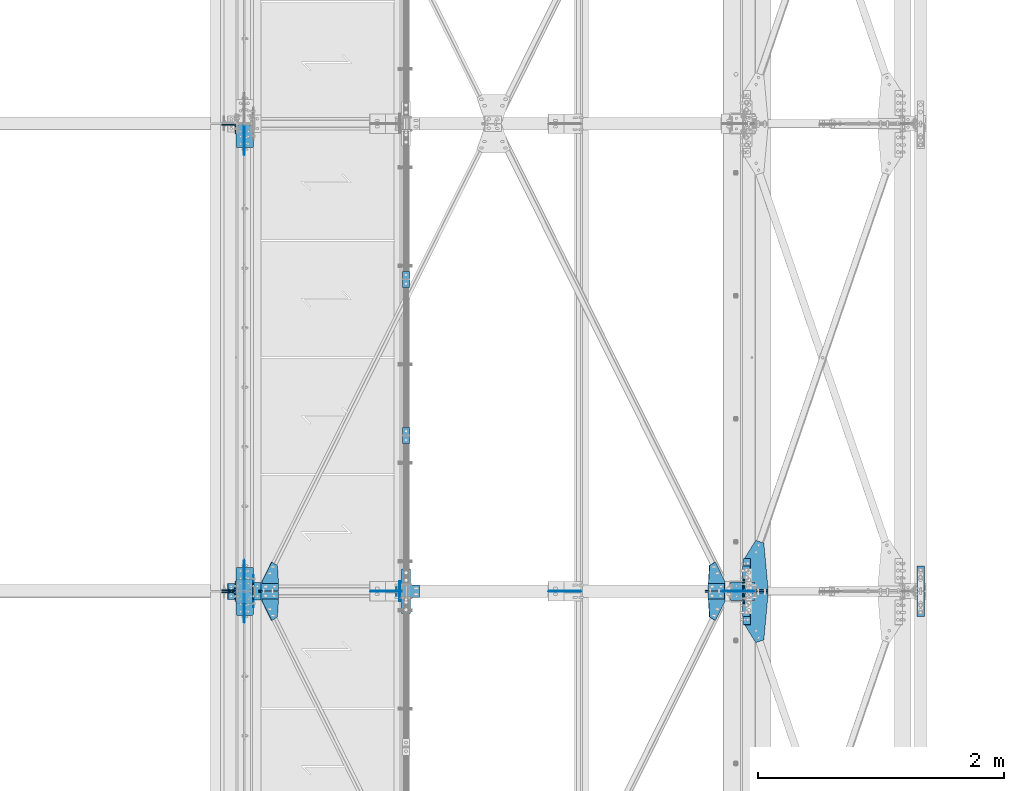
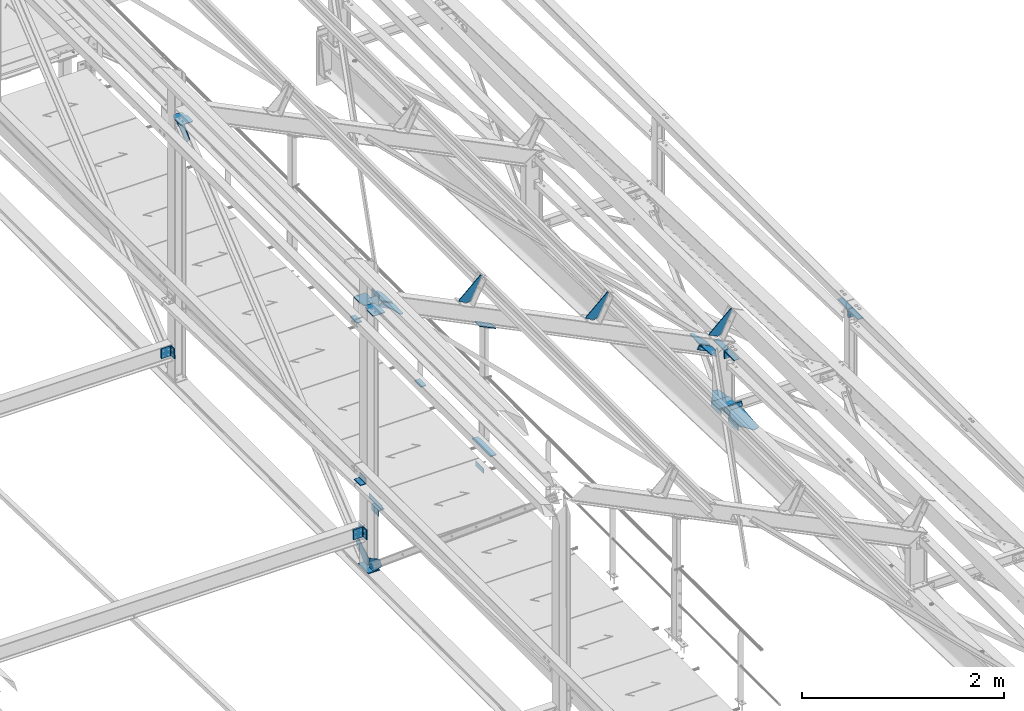
# One storey, part 108 of 496: 30 beams, 10 members, 31 elements without a shape of their own.
"""IFC2X3 building model written with IfcOpenShell, lengths in millimetres."""

from ifc_helpers import new_model, si_unit, frame, frame_2d, origin_with_axes, origin_2d_with_axis, place, context, subcontext, project, spatial, polyline, circle_curve, parameter, trimmed, segment, composite_curve, rectangle, l_section, outline, extrude, material, type_object, element, aggregate, save


model = new_model("IFC2X3")

# Units and contexts
model_context = context("Model", 3, precision=1e-05, world=origin_with_axes())
body_context = subcontext(model_context, "Body", "Model", "MODEL_VIEW")
ifc_project = project(units=[si_unit("LENGTHUNIT", "METRE", prefix="MILLI"), si_unit("AREAUNIT", "SQUARE_METRE"), si_unit("VOLUMEUNIT", "CUBIC_METRE"), si_unit("MASSUNIT", "GRAM", prefix="KILO"), si_unit("TIMEUNIT", "SECOND"), si_unit("PLANEANGLEUNIT", "RADIAN"), si_unit("SOLIDANGLEUNIT", "STERADIAN"), si_unit("THERMODYNAMICTEMPERATUREUNIT", "DEGREE_CELSIUS"), si_unit("LUMINOUSINTENSITYUNIT", "LUMEN")], contexts=[model_context])

# Site, building, storey
site_placement = place(None, origin_with_axes())
site = spatial("IfcSite", under=ifc_project, at=site_placement, CompositionType="ELEMENT")
building_placement = place(site_placement, origin_with_axes())
building = spatial("IfcBuilding", under=site, at=building_placement, Name="Undefined", CompositionType="ELEMENT")
storey_placement = place(building_placement, origin_with_axes())
storey = spatial("IfcBuildingStorey", under=building, at=storey_placement, Name="Undefined", CompositionType="ELEMENT", Elevation=0.0)

# Assembly, beams
assembly_1_placement = place(storey_placement, origin_with_axes())
assembly_1 = element("IfcElementAssembly", 1, at=assembly_1_placement, inside=storey, Name="MAIN COURANTE", AssemblyPlace="NOTDEFINED", PredefinedType="NOTDEFINED")
ifc_material = material(Name="Undefined/S235-E24")
beam_type_1 = type_object("IfcBeamType", PredefinedType="NOTDEFINED")
beam_1_placement = place(assembly_1_placement, frame((35593.9917177843, 8930.00343196749, 8245.00000278714), z_axis=(-1.0, 0.0, 0.0), x_axis=(0.0, -1.0, 0.0)))
beam_1 = element("IfcBeam", 2, at=beam_1_placement, type_object=beam_type_1, material=ifc_material, context=body_context, shape_type="SweptSolid", body=[
    extrude(rectangle(XDim=10.0, YDim=60.0, at=origin_2d_with_axis()), frame((130.0, 0.0, 0.0), z_axis=(-1.0, 0.0, 0.0), x_axis=(0.0, -1.0, 0.0)), (0.0, 0.0, 1.0), 130.0),
])
beam_2_placement = place(assembly_1_placement, frame((35593.9917188389, 10200.0034319675, 8245.00000191645), z_axis=(-1.0, 0.0, 0.0), x_axis=(0.0, -1.0, 0.0)))
beam_2 = element("IfcBeam", 3, at=beam_2_placement, type_object=beam_type_1, material=ifc_material, context=body_context, shape_type="SweptSolid", body=[
    extrude(rectangle(XDim=10.0, YDim=60.0, at=origin_2d_with_axis()), frame((130.0, 0.0, 0.0), z_axis=(-1.0, 0.0, 0.0), x_axis=(0.0, -1.0, 0.0)), (0.0, 0.0, 1.0), 130.0),
])
aggregate(assembly_1, [beam_1, beam_2])

# Assembly, beam
assembly_2_placement = place(storey_placement, origin_with_axes())
assembly_2 = element("IfcElementAssembly", 4, at=assembly_2_placement, inside=storey, AssemblyPlace="NOTDEFINED", PredefinedType="NOTDEFINED")
beam_type_2 = type_object("IfcBeamType", PredefinedType="NOTDEFINED")
beam_3_placement = place(assembly_2_placement, frame((38365.0000000024, 7527.01910210881, 7657.37684430103), z_axis=(0.0, -0.031410887010906, -0.999506556345274), x_axis=(0.0, -0.999506556345276, 0.031410887010852)))
beam_3 = element("IfcBeam", 5, at=beam_3_placement, type_object=beam_type_2, material=ifc_material, context=body_context, shape_type="SweptSolid", body=[
    extrude(l_section(Depth=60.0, Width=60.0, Thickness=6.0, FilletRadius=8.0, EdgeRadius=4.0, at=origin_2d_with_axis()), frame((200.0, 0.0, 0.0), z_axis=(-1.0, 0.0, 0.0), x_axis=(0.0, -1.0, 0.0)), (0.0, 0.0, 1.0), 200.0),
])
aggregate(assembly_2, [beam_3])

assembly_3_placement = place(storey_placement, origin_with_axes())
assembly_3 = element("IfcElementAssembly", 6, at=assembly_3_placement, inside=storey, AssemblyPlace="NOTDEFINED", PredefinedType="NOTDEFINED")
beam_4_placement = place(assembly_3_placement, frame((38365.0000000024, 7866.85133378981, 7646.69722298247), z_axis=(0.0, -0.031410887010906, -0.999506556345274), x_axis=(0.0, -0.999506556345276, 0.031410887010852)))
beam_4 = element("IfcBeam", 7, at=beam_4_placement, type_object=beam_type_2, material=ifc_material, context=body_context, shape_type="SweptSolid", body=[
    extrude(l_section(Depth=60.0, Width=60.0, Thickness=6.0, FilletRadius=8.0, EdgeRadius=4.0, at=origin_2d_with_axis()), frame((200.0, 0.0, 0.0), z_axis=(-1.0, 0.0, 0.0), x_axis=(0.0, -1.0, 0.0)), (0.0, 0.0, 1.0), 200.0),
])
aggregate(assembly_3, [beam_4])

assembly_4_placement = place(storey_placement, origin_with_axes())
assembly_4 = element("IfcElementAssembly", 8, at=assembly_4_placement, inside=storey, Name="TRAVERSE SHED", AssemblyPlace="NOTDEFINED", PredefinedType="NOTDEFINED")
beam_type_3 = type_object("IfcBeamType", PredefinedType="NOTDEFINED")
beam_5_placement = place(assembly_4_placement, frame((38330.0, 7674.80562184453, 7813.81292929363), z_axis=(-1.0, 0.0, 0.0), x_axis=(0.0, -0.999506556345276, 0.031410887010852)))
beam_5 = element("IfcBeam", 9, at=beam_5_placement, type_object=beam_type_3, material=ifc_material, context=body_context, shape_type="SweptSolid", body=[
    extrude(rectangle(XDim=10.0, YDim=200.0, at=origin_2d_with_axis()), frame((149.999995982835, 4.54747350886464e-12, 3.63797880709171e-12), z_axis=(-1.0, 0.0, 0.0), x_axis=(0.0, -1.0, 0.0)), (0.0, 0.0, 1.0), 150.0),
])

assembly_5_placement = place(storey_placement, origin_with_axes())
assembly_5 = element("IfcElementAssembly", 10, at=assembly_5_placement, inside=storey, AssemblyPlace="NOTDEFINED", PredefinedType="NOTDEFINED")
beam_type_4 = type_object("IfcBeamType", PredefinedType="NOTDEFINED")
beam_6_placement = place(assembly_5_placement, frame((34381.5000576363, 7530.0, 7915.0), z_axis=(1.0, 0.0, 0.0), x_axis=(0.0, 1.0, 0.0)))
beam_6 = element("IfcBeam", 11, at=beam_6_placement, type_object=beam_type_4, material=ifc_material, context=body_context, shape_type="SweptSolid", body=[
    extrude(l_section(Depth=70.0, Width=70.0, Thickness=7.0, FilletRadius=9.0, EdgeRadius=4.5, at=origin_2d_with_axis()), frame((140.0, 0.0, 0.0), z_axis=(-1.0, 0.0, 0.0), x_axis=(0.0, -1.0, 0.0)), (0.0, 0.0, 1.0), 140.0),
])
aggregate(assembly_5, [beam_6])

assembly_6_placement = place(storey_placement, origin_with_axes())
assembly_6 = element("IfcElementAssembly", 12, at=assembly_6_placement, inside=storey, AssemblyPlace="NOTDEFINED", PredefinedType="NOTDEFINED")
beam_7_placement = place(assembly_6_placement, frame((34178.5001163161, 7664.81291402424, 8349.41493629771), z_axis=(0.0, 0.0314135610096692, 0.999506472307554), x_axis=(0.0, -0.999506472307554, 0.031413561009669)))
beam_7 = element("IfcBeam", 13, at=beam_7_placement, type_object=beam_type_4, material=ifc_material, context=body_context, shape_type="SweptSolid", body=[
    extrude(l_section(Depth=70.0, Width=70.0, Thickness=7.0, FilletRadius=9.0, EdgeRadius=4.5, at=origin_2d_with_axis()), frame((130.004127993981, 0.0, 9.02084851220212e-16), z_axis=(-1.0, 0.0, 0.0), x_axis=(0.0, -1.0, 0.0)), (0.0, 0.0, 1.0), 130.0),
])
aggregate(assembly_6, [beam_7])

# Assembly, member
assembly_7_placement = place(storey_placement, origin_with_axes())
assembly_7 = element("IfcElementAssembly", 14, at=assembly_7_placement, inside=storey, AssemblyPlace="NOTDEFINED", PredefinedType="NOTDEFINED")
member_type_1 = type_object("IfcMemberType", PredefinedType="NOTDEFINED")
member_1_placement = place(assembly_7_placement, frame((38035.9186042642, 7567.00048471499, 8592.20874331215), z_axis=(0.0, -1.0, 0.0), x_axis=(0.897398510539058, 0.0, -0.441220934773362)))
member_1 = element("IfcMember", 15, at=member_1_placement, type_object=member_type_1, material=ifc_material, context=body_context, shape_type="SweptSolid", body=[
    extrude(l_section(Depth=60.0, Width=60.0, Thickness=6.0, FilletRadius=8.0, EdgeRadius=4.0, at=origin_2d_with_axis()), frame((149.999995982835, 4.54747350886464e-12, 3.63797880709171e-12), z_axis=(-1.0, 0.0, 0.0), x_axis=(0.0, -1.0, 0.0)), (0.0, 0.0, 1.0), 150.0),
])
aggregate(assembly_7, [member_1])

assembly_8_placement = place(storey_placement, origin_with_axes())
assembly_8 = element("IfcElementAssembly", 16, at=assembly_8_placement, inside=storey, AssemblyPlace="NOTDEFINED", PredefinedType="NOTDEFINED")
member_2_placement = place(assembly_8_placement, frame((38170.5284284906, 7633.00028154396, 8526.02570190095), z_axis=(0.0, 1.0, 0.0), x_axis=(-0.897398834350847, -3.60000012672484e-08, 0.441220276172504)))
member_2 = element("IfcMember", 17, at=member_2_placement, type_object=member_type_1, material=ifc_material, context=body_context, shape_type="SweptSolid", body=[
    extrude(l_section(Depth=60.0, Width=60.0, Thickness=6.0, FilletRadius=8.0, EdgeRadius=4.0, at=origin_2d_with_axis()), frame((149.999995982835, 4.54747350886464e-12, 3.63797880709171e-12), z_axis=(-1.0, 0.0, 0.0), x_axis=(0.0, -1.0, 0.0)), (0.0, 0.0, 1.0), 150.0),
])
aggregate(assembly_8, [member_2])

assembly_9_placement = place(storey_placement, origin_with_axes())
assembly_9 = element("IfcElementAssembly", 18, at=assembly_9_placement, inside=storey, AssemblyPlace="NOTDEFINED", PredefinedType="NOTDEFINED")
member_3_placement = place(assembly_9_placement, frame((34407.7040963335, 7567.00042689714, 10376.0796849426), z_axis=(0.0, -1.0, 0.0), x_axis=(0.897398510539058, 0.0, -0.441220934773362)))
member_3 = element("IfcMember", 19, at=member_3_placement, type_object=member_type_1, material=ifc_material, context=body_context, shape_type="SweptSolid", body=[
    extrude(l_section(Depth=60.0, Width=60.0, Thickness=6.0, FilletRadius=8.0, EdgeRadius=4.0, at=origin_2d_with_axis()), frame((149.999995982835, 4.54747350886464e-12, 3.63797880709171e-12), z_axis=(-1.0, 0.0, 0.0), x_axis=(0.0, -1.0, 0.0)), (0.0, 0.0, 1.0), 150.0),
])
aggregate(assembly_9, [member_3])

assembly_10_placement = place(storey_placement, origin_with_axes())
assembly_10 = element("IfcElementAssembly", 20, at=assembly_10_placement, inside=storey, AssemblyPlace="NOTDEFINED", PredefinedType="NOTDEFINED")
member_4_placement = place(assembly_10_placement, frame((34542.3138606223, 7633.00022373686, 10309.896521744), z_axis=(0.0, 1.0, 0.0), x_axis=(-0.897398510539055, -1.29999898490537e-08, 0.441220934773368)))
member_4 = element("IfcMember", 21, at=member_4_placement, type_object=member_type_1, material=ifc_material, context=body_context, shape_type="SweptSolid", body=[
    extrude(l_section(Depth=60.0, Width=60.0, Thickness=6.0, FilletRadius=8.0, EdgeRadius=4.0, at=origin_2d_with_axis()), frame((149.999995982835, 4.54747350886464e-12, 3.63797880709171e-12), z_axis=(-1.0, 0.0, 0.0), x_axis=(0.0, -1.0, 0.0)), (0.0, 0.0, 1.0), 150.0),
])
aggregate(assembly_10, [member_4])

# Assembly, beam
assembly_11_placement = place(storey_placement, origin_with_axes())
assembly_11 = element("IfcElementAssembly", 22, at=assembly_11_placement, inside=storey, Name="SHED", AssemblyPlace="NOTDEFINED", PredefinedType="NOTDEFINED")
beam_type_5 = type_object("IfcBeamType", PredefinedType="NOTDEFINED")
beam_8_placement = place(assembly_11_placement, frame((38167.3881652729, 7600.0, 8712.54750741415), z_axis=(0.0, -1.0, 0.0), x_axis=(-0.441220935974661, 0.0, -0.89739850994842)))
beam_8 = element("IfcBeam", 23, at=beam_8_placement, type_object=beam_type_5, material=ifc_material, context=body_context, shape_type="SweptSolid", body=[
    extrude(outline(polyline([(0.0, 0.0), (20.0, 0.0), (20.0000000002019, 109.999999999982), (-9.99999999974731, 139.99998998623), (-300.0000000002, 139.999893186625), (-300.000000000226, 119.999893186643), (0.0, 0.0)])), frame((0.0, 0.0, -4.0), z_axis=(0.0, 0.0, 1.0), x_axis=(1.0, 0.0, 0.0)), (0.0, 0.0, 1.0), 8.0),
])
aggregate(assembly_11, [beam_8])

assembly_12_placement = place(storey_placement, origin_with_axes())
assembly_12 = element("IfcElementAssembly", 24, at=assembly_12_placement, inside=storey, Name="SHED", AssemblyPlace="NOTDEFINED", PredefinedType="NOTDEFINED")
beam_9_placement = place(assembly_12_placement, frame((36758.937741054, 7600.0, 9405.03563331224), z_axis=(0.0, -1.0, 0.0), x_axis=(-0.441220935974661, 0.0, -0.89739850994842)))
beam_9 = element("IfcBeam", 25, at=beam_9_placement, type_object=beam_type_5, material=ifc_material, context=body_context, shape_type="SweptSolid", body=[
    extrude(outline(polyline([(0.0, 0.0), (20.0, 0.0), (20.0000000002019, 109.999999999982), (-9.99999999974731, 139.99998998623), (-300.0000000002, 139.999893186625), (-300.000000000226, 119.999893186643), (0.0, 0.0)])), frame((0.0, 0.0, -4.0), z_axis=(0.0, 0.0, 1.0), x_axis=(1.0, 0.0, 0.0)), (0.0, 0.0, 1.0), 8.0),
])
aggregate(assembly_12, [beam_9])

assembly_13_placement = place(storey_placement, origin_with_axes())
assembly_13 = element("IfcElementAssembly", 26, at=assembly_13_placement, inside=storey, Name="SHED", AssemblyPlace="NOTDEFINED", PredefinedType="NOTDEFINED")
beam_10_placement = place(assembly_13_placement, frame((35310.1044072469, 7600.0, 10117.3786897729), z_axis=(0.0, -1.0, 0.0), x_axis=(-0.441220935974661, 0.0, -0.89739850994842)))
beam_10 = element("IfcBeam", 27, at=beam_10_placement, type_object=beam_type_5, material=ifc_material, context=body_context, shape_type="SweptSolid", body=[
    extrude(outline(polyline([(0.0, 0.0), (20.0, 0.0), (20.0000000002019, 109.999999999982), (-9.99999999974731, 139.99998998623), (-300.0000000002, 139.999893186625), (-300.000000000226, 119.999893186643), (0.0, 0.0)])), frame((0.0, 0.0, -4.0), z_axis=(0.0, 0.0, 1.0), x_axis=(1.0, 0.0, 0.0)), (0.0, 0.0, 1.0), 8.0),
])
aggregate(assembly_13, [beam_10])

# Assembly, member
assembly_14_placement = place(storey_placement, origin_with_axes())
assembly_14 = element("IfcElementAssembly", 28, at=assembly_14_placement, inside=storey, AssemblyPlace="NOTDEFINED", PredefinedType="NOTDEFINED")
member_type_2 = type_object("IfcMemberType", PredefinedType="NOTDEFINED")
member_5_placement = place(assembly_14_placement, frame((38435.0, 7651.71824061339, 7709.48564043715), z_axis=(1.0, 0.0, 0.0), x_axis=(0.0, 0.031410887010906, 0.999506556345274)))
member_5 = element("IfcMember", 29, at=member_5_placement, type_object=member_type_2, material=ifc_material, context=body_context, shape_type="SweptSolid", body=[
    extrude(l_section(Depth=200.0, Width=100.0, Thickness=10.0, FilletRadius=15.0, EdgeRadius=7.5, at=origin_2d_with_axis()), frame((60.0, 0.0, 0.0), z_axis=(-1.0, 0.0, 0.0), x_axis=(0.0, -1.0, 0.0)), (0.0, 0.0, 1.0), 60.0),
])
aggregate(assembly_14, [member_5])

assembly_15_placement = place(storey_placement, origin_with_axes())
assembly_15 = element("IfcElementAssembly", 30, at=assembly_15_placement, inside=storey, AssemblyPlace="NOTDEFINED", PredefinedType="NOTDEFINED")
member_6_placement = place(assembly_15_placement, frame((38435.0000000001, 7547.65438248849, 7772.78568749962), z_axis=(1.0, 0.0, 0.0), x_axis=(0.0, -0.031410887010906, -0.999506556345274)))
member_6 = element("IfcMember", 31, at=member_6_placement, type_object=member_type_2, material=ifc_material, context=body_context, shape_type="SweptSolid", body=[
    extrude(l_section(Depth=200.0, Width=100.0, Thickness=10.0, FilletRadius=15.0, EdgeRadius=7.5, at=origin_2d_with_axis()), frame((60.0, 0.0, 0.0), z_axis=(-1.0, 0.0, 0.0), x_axis=(0.0, -1.0, 0.0)), (0.0, 0.0, 1.0), 60.0),
])
aggregate(assembly_15, [member_6])

# Assembly, beam
assembly_16_placement = place(storey_placement, origin_with_axes())
assembly_16 = element("IfcElementAssembly", 32, at=assembly_16_placement, inside=storey, Name="MONTANT", AssemblyPlace="NOTDEFINED", PredefinedType="NOTDEFINED")
beam_type_6 = type_object("IfcBeamType", PredefinedType="NOTDEFINED")
beam_11_placement = place(assembly_16_placement, frame((34280.0, 7700.00000000017, 7255.00000000019), z_axis=(1.0, 0.0, 0.0), x_axis=(0.0, -1.0, 0.0)))
beam_11 = element("IfcBeam", 33, at=beam_11_placement, type_object=beam_type_6, material=ifc_material, context=body_context, shape_type="SweptSolid", body=[
    extrude(rectangle(XDim=10.0, YDim=133.0, at=origin_2d_with_axis()), frame((200.0, 0.0, 0.0), z_axis=(-1.0, 0.0, 0.0), x_axis=(0.0, -1.0, 0.0)), (0.0, 0.0, 1.0), 200.0),
])

assembly_17_placement = place(storey_placement, origin_with_axes())
assembly_17 = element("IfcElementAssembly", 34, at=assembly_17_placement, inside=storey, AssemblyPlace="NOTDEFINED", PredefinedType="NOTDEFINED")
beam_type_7 = type_object("IfcBeamType", PredefinedType="NOTDEFINED")
beam_12_placement = place(assembly_17_placement, frame((39805.0, 7703.5, 8400.0), z_axis=(0.0, 1.0, 0.0), x_axis=(-1.0, 0.0, 0.0)))
beam_12 = element("IfcBeam", 35, at=beam_12_placement, type_object=beam_type_7, material=ifc_material, context=body_context, shape_type="SweptSolid", body=[
    extrude(l_section(Depth=200.0, Width=100.0, Thickness=10.0, FilletRadius=15.0, EdgeRadius=7.5, at=origin_2d_with_axis()), frame((60.0, 0.0, 0.0), z_axis=(-1.0, 0.0, 0.0), x_axis=(0.0, -1.0, 0.0)), (0.0, 0.0, 1.0), 60.0),
])
aggregate(assembly_17, [beam_12])

assembly_18_placement = place(storey_placement, origin_with_axes())
assembly_18 = element("IfcElementAssembly", 36, at=assembly_18_placement, inside=storey, AssemblyPlace="NOTDEFINED", PredefinedType="NOTDEFINED")
beam_13_placement = place(assembly_18_placement, frame((39745.0, 7496.5, 8400.0), z_axis=(0.0, -1.0, 0.0), x_axis=(1.0, 0.0, 0.0)))
beam_13 = element("IfcBeam", 37, at=beam_13_placement, type_object=beam_type_7, material=ifc_material, context=body_context, shape_type="SweptSolid", body=[
    extrude(l_section(Depth=200.0, Width=100.0, Thickness=10.0, FilletRadius=15.0, EdgeRadius=7.5, at=origin_2d_with_axis()), frame((60.0, 0.0, 0.0), z_axis=(-1.0, 0.0, 0.0), x_axis=(0.0, -1.0, 0.0)), (0.0, 0.0, 1.0), 60.0),
])
aggregate(assembly_18, [beam_13])

assembly_19_placement = place(storey_placement, origin_with_axes())
assembly_19 = element("IfcElementAssembly", 38, at=assembly_19_placement, inside=storey, AssemblyPlace="NOTDEFINED", PredefinedType="NOTDEFINED")
beam_14_placement = place(assembly_19_placement, frame((38390.0, 7703.5, 8400.0), z_axis=(0.0, 1.0, 0.0), x_axis=(-1.0, 0.0, 0.0)))
beam_14 = element("IfcBeam", 39, at=beam_14_placement, type_object=beam_type_7, material=ifc_material, context=body_context, shape_type="SweptSolid", body=[
    extrude(l_section(Depth=200.0, Width=100.0, Thickness=10.0, FilletRadius=15.0, EdgeRadius=7.5, at=origin_2d_with_axis()), frame((60.0, 0.0, 0.0), z_axis=(-1.0, 0.0, 0.0), x_axis=(0.0, -1.0, 0.0)), (0.0, 0.0, 1.0), 60.0),
])
aggregate(assembly_19, [beam_14])

assembly_20_placement = place(storey_placement, origin_with_axes())
assembly_20 = element("IfcElementAssembly", 40, at=assembly_20_placement, inside=storey, AssemblyPlace="NOTDEFINED", PredefinedType="NOTDEFINED")
beam_15_placement = place(assembly_20_placement, frame((38330.0, 7496.5, 8400.0), z_axis=(0.0, -1.0, 0.0), x_axis=(1.0, 0.0, 0.0)))
beam_15 = element("IfcBeam", 41, at=beam_15_placement, type_object=beam_type_7, material=ifc_material, context=body_context, shape_type="SweptSolid", body=[
    extrude(l_section(Depth=200.0, Width=100.0, Thickness=10.0, FilletRadius=15.0, EdgeRadius=7.5, at=origin_2d_with_axis()), frame((60.0, 0.0, 0.0), z_axis=(-1.0, 0.0, 0.0), x_axis=(0.0, -1.0, 0.0)), (0.0, 0.0, 1.0), 60.0),
])
aggregate(assembly_20, [beam_15])

# Assembly, member
assembly_21_placement = place(storey_placement, origin_with_axes())
assembly_21 = element("IfcElementAssembly", 42, at=assembly_21_placement, inside=storey, AssemblyPlace="NOTDEFINED", PredefinedType="NOTDEFINED")
member_type_3 = type_object("IfcMemberType", PredefinedType="NOTDEFINED")
member_7_placement = place(assembly_21_placement, frame((35511.0197434437, 7600.00000001334, 9756.72720417295), z_axis=(0.0, -1.0, 0.0), x_axis=(0.897398510539058, 0.0, -0.441220934773362)))
member_7 = element("IfcMember", 43, at=member_7_placement, type_object=member_type_3, material=ifc_material, context=body_context, shape_type="SweptSolid", body=[
    extrude(rectangle(XDim=10.0, YDim=100.0, at=origin_2d_with_axis()), frame((210.000000000491, 0.0, 1.81898940354586e-12), z_axis=(-1.0, 0.0, 0.0), x_axis=(0.0, -1.0, 0.0)), (0.0, 0.0, 1.0), 210.0),
])

# Assembly, beams
assembly_22_placement = place(storey_placement, origin_with_axes())
assembly_22 = element("IfcElementAssembly", 44, at=assembly_22_placement, inside=storey, AssemblyPlace="NOTDEFINED", PredefinedType="NOTDEFINED")
beam_type_8 = type_object("IfcBeamType", PredefinedType="NOTDEFINED")
beam_16_placement = place(assembly_22_placement, frame((35542.9917140619, 7520.0, 7985.0), z_axis=(-1.0, 0.0, 0.0), x_axis=(0.0, 0.0, 1.0)))
beam_16 = element("IfcBeam", 45, at=beam_16_placement, type_object=beam_type_8, material=ifc_material, context=body_context, shape_type="SweptSolid", body=[
    extrude(outline(polyline([(0.0, 0.0), (60.0, 0.0), (60.0, 159.999984741211), (0.0, 159.999984741211), (0.0, 0.0)])), frame((0.0, 0.0, -3.0), z_axis=(0.0, 0.0, 1.0), x_axis=(1.0, 0.0, 0.0)), (0.0, 0.0, 1.0), 6.0),
])
beam_17_placement = place(assembly_22_placement, frame((34354.991943003, 7470.0, 7985.0), z_axis=(-1.0, 0.0, 0.0), x_axis=(0.0, 0.0, 1.0)))
beam_17 = element("IfcBeam", 46, at=beam_17_placement, type_object=beam_type_8, material=ifc_material, context=body_context, shape_type="SweptSolid", body=[
    extrude(outline(polyline([(0.0, 0.0), (60.0, 0.0), (60.0, 260.0), (0.0, 260.0), (0.0, 0.0)])), frame((0.0, 0.0, -3.0), z_axis=(0.0, 0.0, 1.0), x_axis=(1.0, 0.0, 0.0)), (0.0, 0.0, 1.0), 6.0),
])
aggregate(assembly_22, [beam_16, beam_17])

# Beam
beam_type_9 = type_object("IfcBeamType", PredefinedType="NOTDEFINED")
beam_18_placement = place(assembly_21_placement, frame((35593.9917140619, 7780.00010616256, 8245.00000367738), z_axis=(1.0, 0.0, 0.0), x_axis=(0.0, -1.0, 0.0)))
beam_18 = element("IfcBeam", 47, at=beam_18_placement, type_object=beam_type_9, material=ifc_material, context=body_context, shape_type="SweptSolid", body=[
    extrude(rectangle(XDim=10.0, YDim=70.0, at=origin_2d_with_axis()), frame((360.000000000004, 0.0, 0.0), z_axis=(-1.0, 0.0, 0.0), x_axis=(0.0, -1.0, 0.0)), (0.0, 0.0, 1.0), 360.0),
])

aggregate(assembly_21, [member_7, beam_18])

beam_type_10 = type_object("IfcBeamType", PredefinedType="NOTDEFINED")
beam_19_placement = place(assembly_4_placement, frame((34351.5, 7600.0, 10548.0682550821), z_axis=(0.0, -1.0, 0.0), x_axis=(0.0, 0.0, -1.0)))
beam_19 = element("IfcBeam", 48, at=beam_19_placement, type_object=beam_type_10, material=ifc_material, context=body_context, shape_type="SweptSolid", body=[
    extrude(rectangle(XDim=10.0, YDim=140.0, at=origin_2d_with_axis()), frame((213.394604237721, 0.0, 0.0), z_axis=(-1.0, 0.0, 0.0), x_axis=(0.0, -1.0, 0.0)), (0.0, 0.0, 1.0), 213.39),
])

aggregate(assembly_4, [beam_5, beam_19])

# Assembly, beam
assembly_23_placement = place(storey_placement, origin_with_axes())
assembly_23 = element("IfcElementAssembly", 49, at=assembly_23_placement, inside=storey, AssemblyPlace="NOTDEFINED", PredefinedType="NOTDEFINED")
beam_type_11 = type_object("IfcBeamType", PredefinedType="NOTDEFINED")
beam_20_placement = place(assembly_23_placement, frame((38059.1847717179, 7390.7417709218, 8617.5425833761), z_axis=(0.441221071222121, 0.0, 0.897398443451739), x_axis=(0.784869567232957, -0.48483568373157, -0.385893926114537)))
beam_20 = element("IfcBeam", 50, at=beam_20_placement, type_object=beam_type_11, material=ifc_material, context=body_context, shape_type="SweptSolid", body=[
    extrude(outline(polyline([(0.0, 0.0), (60.0, 0.0), (60.000000001357, 181.13842773447), (27.5527534497232, 239.6707305907), (-103.638031004382, 166.945343016534), (-79.3962478622052, 123.215103148526), (0.0, 0.0)])), frame((0.0, 0.0, -3.0), z_axis=(0.0, 0.0, 1.0), x_axis=(1.0, 0.0, 0.0)), (0.0, 0.0, 1.0), 6.0),
])
aggregate(assembly_23, [beam_20])

assembly_24_placement = place(storey_placement, origin_with_axes())
assembly_24 = element("IfcElementAssembly", 51, at=assembly_24_placement, inside=storey, AssemblyPlace="NOTDEFINED", PredefinedType="NOTDEFINED")
beam_21_placement = place(assembly_24_placement, frame((38059.1847654394, 7809.25899063082, 8617.54258337552), z_axis=(-0.441220935974661, 0.0, -0.89739850994842), x_axis=(0.78486954223706, 0.48483572817386, -0.385893921116557)))
beam_21 = element("IfcBeam", 52, at=beam_21_placement, type_object=beam_type_11, material=ifc_material, context=body_context, shape_type="SweptSolid", body=[
    extrude(outline(polyline([(0.0, 0.0), (60.0, 0.0), (60.000000001357, 181.13842773447), (27.5527534497232, 239.6707305907), (-103.638031004382, 166.945343016534), (-79.3962478622052, 123.215103148526), (0.0, 0.0)])), frame((0.0, 0.0, -3.0), z_axis=(0.0, 0.0, 1.0), x_axis=(1.0, 0.0, 0.0)), (0.0, 0.0, 1.0), 6.0),
])
aggregate(assembly_24, [beam_21])

assembly_25_placement = place(storey_placement, origin_with_axes())
assembly_25 = element("IfcElementAssembly", 53, at=assembly_25_placement, inside=storey, AssemblyPlace="NOTDEFINED", PredefinedType="NOTDEFINED")
beam_22_placement = place(assembly_25_placement, frame((34548.1683232351, 7390.74171824433, 10343.791111071), z_axis=(-0.441220935974661, 0.0, -0.89739850994842), x_axis=(-0.784869552886434, -0.484835707091843, 0.385893925944167)))
beam_22 = element("IfcBeam", 54, at=beam_22_placement, type_object=beam_type_11, material=ifc_material, context=body_context, shape_type="SweptSolid", body=[
    extrude(outline(polyline([(0.0, 0.0), (60.0, 0.0), (60.000000001357, 181.13842773447), (27.5527534497232, 239.6707305907), (-103.638031004382, 166.945343016534), (-79.3962478622052, 123.215103148526), (0.0, 0.0)])), frame((0.0, 0.0, -3.0), z_axis=(0.0, 0.0, 1.0), x_axis=(1.0, 0.0, 0.0)), (0.0, 0.0, 1.0), 6.0),
])
aggregate(assembly_25, [beam_22])

assembly_26_placement = place(storey_placement, origin_with_axes())
assembly_26 = element("IfcElementAssembly", 55, at=assembly_26_placement, inside=storey, AssemblyPlace="NOTDEFINED", PredefinedType="NOTDEFINED")
beam_23_placement = place(assembly_26_placement, frame((34548.1683169554, 7809.25893795247, 10343.7911110713), z_axis=(0.441221071222121, 0.0, 0.897398443451739), x_axis=(-0.784869556946141, 0.484835704476116, 0.38589392097352)))
beam_23 = element("IfcBeam", 56, at=beam_23_placement, type_object=beam_type_11, material=ifc_material, context=body_context, shape_type="SweptSolid", body=[
    extrude(outline(polyline([(0.0, 0.0), (60.0, 0.0), (60.000000001357, 181.13842773447), (27.5527534497232, 239.6707305907), (-103.638031004382, 166.945343016534), (-79.3962478622052, 123.215103148526), (0.0, 0.0)])), frame((0.0, 0.0, -3.0), z_axis=(0.0, 0.0, 1.0), x_axis=(1.0, 0.0, 0.0)), (0.0, 0.0, 1.0), 6.0),
])
aggregate(assembly_26, [beam_23])

assembly_27_placement = place(storey_placement, origin_with_axes())
assembly_27 = element("IfcElementAssembly", 57, at=assembly_27_placement, inside=storey, AssemblyPlace="NOTDEFINED", PredefinedType="NOTDEFINED")
beam_type_12 = type_object("IfcBeamType", PredefinedType="NOTDEFINED")
beam_24_placement = place(assembly_27_placement, frame((38435.2715292386, 8013.86021399275, 7675.09357304896), z_axis=(0.0, 0.031410887010906, 0.999506556345274), x_axis=(-0.525777576315004, -0.850202359509391, 0.0267186850160107)))
beam_24 = element("IfcBeam", 58, at=beam_24_placement, type_object=beam_type_12, material=ifc_material, context=body_context, shape_type="SweptSolid", body=[
    extrude(outline(polyline([(0.0, 0.0), (171.691329954992, 6.33008312433958e-10), (631.027099607662, 283.920135501994), (707.794555662011, 437.495086674662), (653.704650876763, 481.928009037783), (328.681274412298, 320.403106691963), (274.241485594019, 286.753295900591), (-15.5598268524991, 68.2487487800354), (0.0, 0.0)])), frame((0.0, 0.0, -3.0), z_axis=(0.0, 0.0, 1.0), x_axis=(1.0, 0.0, 0.0)), (0.0, 0.0, 1.0), 6.0),
])
aggregate(assembly_27, [beam_24])

# Assembly, member
assembly_28_placement = place(storey_placement, origin_with_axes())
assembly_28 = element("IfcElementAssembly", 59, at=assembly_28_placement, inside=storey, AssemblyPlace="NOTDEFINED", PredefinedType="NOTDEFINED")
member_type_4 = type_object("IfcMemberType", PredefinedType="NOTDEFINED")
member_8_placement = place(assembly_28_placement, frame((34153.5000000005, 7644.86435677144, 7769.73062464733), z_axis=(-1.0, 0.0, 0.0), x_axis=(0.0, -0.031410887010906, -0.999506556345274)))
member_8 = element("IfcMember", 60, at=member_8_placement, type_object=member_type_4, material=ifc_material, context=body_context, shape_type="SweptSolid", body=[
    extrude(l_section(Depth=120.0, Width=80.0, Thickness=10.0, FilletRadius=11.0, EdgeRadius=5.5, at=origin_2d_with_axis()), frame((120.0, 0.0, 0.0), z_axis=(-1.0, 0.0, 0.0), x_axis=(0.0, -1.0, 0.0)), (0.0, 0.0, 1.0), 120.0),
])
aggregate(assembly_28, [member_8])

assembly_29_placement = place(storey_placement, origin_with_axes())
assembly_29 = element("IfcElementAssembly", 61, at=assembly_29_placement, inside=storey, AssemblyPlace="NOTDEFINED", PredefinedType="NOTDEFINED")
member_9_placement = place(assembly_29_placement, frame((34153.5000000006, 7555.1365857944, 7652.49123097112), z_axis=(-1.0, 0.0, 0.0), x_axis=(0.0, 0.031410887010906, 0.999506556345274)))
member_9 = element("IfcMember", 62, at=member_9_placement, type_object=member_type_4, material=ifc_material, context=body_context, shape_type="SweptSolid", body=[
    extrude(l_section(Depth=120.0, Width=80.0, Thickness=10.0, FilletRadius=11.0, EdgeRadius=5.5, at=origin_2d_with_axis()), frame((120.0, 0.0, 0.0), z_axis=(-1.0, 0.0, 0.0), x_axis=(0.0, -1.0, 0.0)), (0.0, 0.0, 1.0), 120.0),
])
aggregate(assembly_29, [member_9])

assembly_30_placement = place(storey_placement, origin_with_axes())
assembly_30 = element("IfcElementAssembly", 63, at=assembly_30_placement, inside=storey, AssemblyPlace="NOTDEFINED", PredefinedType="NOTDEFINED")
member_10_placement = place(assembly_30_placement, frame((34153.5000000006, 11355.1365315396, 7533.0696751278), z_axis=(-1.0, 0.0, 0.0), x_axis=(0.0, 0.031410887010906, 0.999506556345274)))
member_10 = element("IfcMember", 64, at=member_10_placement, type_object=member_type_4, material=ifc_material, context=body_context, shape_type="SweptSolid", body=[
    extrude(l_section(Depth=120.0, Width=80.0, Thickness=10.0, FilletRadius=11.0, EdgeRadius=5.5, at=origin_2d_with_axis()), frame((120.0, 0.0, 0.0), z_axis=(-1.0, 0.0, 0.0), x_axis=(0.0, -1.0, 0.0)), (0.0, 0.0, 1.0), 120.0),
])
aggregate(assembly_30, [member_10])

# Assembly, beam
assembly_31_placement = place(storey_placement, origin_with_axes())
assembly_31 = element("IfcElementAssembly", 65, at=assembly_31_placement, inside=storey, Name="MONTANT", AssemblyPlace="NOTDEFINED", PredefinedType="NOTDEFINED")
beam_type_13 = type_object("IfcBeamType", PredefinedType="NOTDEFINED")
beam_25_placement = place(assembly_31_placement, frame((34280.0, 11279.9969221117, 10413.0), z_axis=(-1.0, 0.0, 0.0), x_axis=(0.0, 1.0, 0.0)))
beam_25 = element("IfcBeam", 66, at=beam_25_placement, type_object=beam_type_13, material=ifc_material, context=body_context, shape_type="SweptSolid", body=[
    extrude(outline(polyline([(0.0, 0.0), (97.25, 0.0), (117.25, 20.0), (117.25, 100.0), (-84.6368789672852, 212.985397338867), (-135.912002563477, 151.578063964844), (0.0, 0.0)])), frame((0.0, 0.0, -4.0), z_axis=(0.0, 0.0, 1.0), x_axis=(1.0, 0.0, 0.0)), (0.0, 0.0, 1.0), 8.0),
])

# Beam
beam_type_14 = type_object("IfcBeamType", PredefinedType="NOTDEFINED")
beam_26_placement = place(assembly_16_placement, frame((34280.0, 7597.25, 7360.0), z_axis=(-1.0, 0.0, 0.0), x_axis=(0.0, 0.0, -1.0)))
beam_26 = element("IfcBeam", 67, at=beam_26_placement, type_object=beam_type_14, material=ifc_material, context=body_context, shape_type="SweptSolid", body=[
    extrude(outline(polyline([(0.0, 0.0), (80.00000000008, 8.00355337560177e-11), (100.0, 20.0), (100.0, 97.25), (-51.5780563354492, 253.165084838867), (-112.985397338867, 201.88996887207), (0.0, 0.0)])), frame((0.0, 0.0, -4.0), z_axis=(0.0, 0.0, 1.0), x_axis=(1.0, 0.0, 0.0)), (0.0, 0.0, 1.0), 8.0),
])

beam_27_placement = place(assembly_16_placement, frame((34280.0, 7700.0, 7260.0), z_axis=(-1.0, 0.0, 0.0), x_axis=(0.0, -1.0, 0.0)))
beam_27 = element("IfcBeam", 68, at=beam_27_placement, type_object=beam_type_14, material=ifc_material, context=body_context, shape_type="SweptSolid", body=[
    extrude(outline(polyline([(0.0, 0.0), (77.25, 0.0), (97.25, 20.0), (97.25, 100.0), (-104.639953613281, 212.985397338867), (-155.915084838867, 151.578063964844), (0.0, 0.0)])), frame((0.0, 0.0, -4.0), z_axis=(0.0, 0.0, 1.0), x_axis=(1.0, 0.0, 0.0)), (0.0, 0.0, 1.0), 8.0),
])

beam_type_15 = type_object("IfcBeamType", PredefinedType="NOTDEFINED")
beam_28_placement = place(assembly_16_placement, frame((34213.5, 7404.99692211173, 10418.0), z_axis=(0.0, 0.0, -1.0), x_axis=(0.0, 1.0, 0.0)))
beam_28 = element("IfcBeam", 69, at=beam_28_placement, type_object=beam_type_15, material=ifc_material, Name="PLAT", context=body_context, shape_type="SweptSolid", body=[
    extrude(outline(composite_curve([segment(trimmed(circle_curve(frame_2d((10.0, 10.0), x_axis=(-1.0, 0.0)), 10.0), [parameter(0.0)], [parameter(1.5707963267949)], True, "PARAMETER"), True, "CONTINUOUS"), segment(polyline([(9.99999999997453, 6.91215973347425e-11), (124.5, 0.0), (124.5, 9.0), (172.25, 9.0), (192.25, 29.0), (192.25, 104.0), (172.25, 124.0), (124.0, 124.0), (124.0, 140.0), (10.0, 140.0)]), True, "CONTINUOUS"), segment(trimmed(circle_curve(frame_2d((10.0, 130.0), x_axis=(0.0, 1.0)), 10.0), [parameter(0.0)], [parameter(1.5707963267949)], True, "PARAMETER"), True, "CONTINUOUS"), segment(polyline([(0.0, 130.0), (-1.81898940354586e-10, 10.0000000000073)]), True, "CONTINUOUS")], self_intersect=True)), frame((0.0, 0.0, -5.0), z_axis=(0.0, 0.0, 1.0), x_axis=(1.0, 0.0, 0.0)), (0.0, 0.0, 1.0), 10.0),
])

beam_29_placement = place(assembly_16_placement, frame((34213.5, 7795.0, 10418.0), z_axis=(0.0, 0.0, 1.0), x_axis=(0.0, -1.0, 0.0)))
beam_29 = element("IfcBeam", 70, at=beam_29_placement, type_object=beam_type_15, material=ifc_material, Name="PLAT", context=body_context, shape_type="SweptSolid", body=[
    extrude(outline(composite_curve([segment(trimmed(circle_curve(frame_2d((10.0, 10.0), x_axis=(-1.0, 0.0)), 10.0), [parameter(0.0)], [parameter(1.5707963267949)], True, "PARAMETER"), True, "CONTINUOUS"), segment(polyline([(9.99999999997453, 6.91215973347425e-11), (124.5, 0.0), (124.5, 9.0), (172.25, 9.0), (192.25, 29.0), (192.25, 104.0), (172.25, 124.0), (124.0, 124.0), (124.0, 140.0), (10.0, 140.0)]), True, "CONTINUOUS"), segment(trimmed(circle_curve(frame_2d((10.0, 130.0), x_axis=(0.0, 1.0)), 10.0), [parameter(0.0)], [parameter(1.5707963267949)], True, "PARAMETER"), True, "CONTINUOUS"), segment(polyline([(0.0, 130.0), (-1.81898940354586e-10, 10.0000000000073)]), True, "CONTINUOUS")], self_intersect=True)), frame((0.0, 0.0, -5.0), z_axis=(0.0, 0.0, 1.0), x_axis=(1.0, 0.0, 0.0)), (0.0, 0.0, 1.0), 10.0),
])

aggregate(assembly_16, [beam_28, beam_29, beam_26, beam_27, beam_11])

beam_30_placement = place(assembly_31_placement, frame((34213.5, 11204.9969221117, 10418.0), z_axis=(0.0, 0.0, -1.0), x_axis=(0.0, 1.0, 0.0)))
beam_30 = element("IfcBeam", 71, at=beam_30_placement, type_object=beam_type_15, material=ifc_material, Name="PLAT", context=body_context, shape_type="SweptSolid", body=[
    extrude(outline(composite_curve([segment(trimmed(circle_curve(frame_2d((10.0, 10.0), x_axis=(-1.0, 0.0)), 10.0), [parameter(0.0)], [parameter(1.5707963267949)], True, "PARAMETER"), True, "CONTINUOUS"), segment(polyline([(9.99999999997453, 6.91215973347425e-11), (124.5, 0.0), (124.5, 9.0), (172.25, 9.0), (192.25, 29.0), (192.25, 104.0), (172.25, 124.0), (124.0, 124.0), (124.0, 140.0), (10.0, 140.0)]), True, "CONTINUOUS"), segment(trimmed(circle_curve(frame_2d((10.0, 130.0), x_axis=(0.0, 1.0)), 10.0), [parameter(0.0)], [parameter(1.5707963267949)], True, "PARAMETER"), True, "CONTINUOUS"), segment(polyline([(0.0, 130.0), (-1.81898940354586e-10, 10.0000000000073)]), True, "CONTINUOUS")], self_intersect=True)), frame((0.0, 0.0, -5.0), z_axis=(0.0, 0.0, 1.0), x_axis=(1.0, 0.0, 0.0)), (0.0, 0.0, 1.0), 10.0),
])

aggregate(assembly_31, [beam_25, beam_30])

save(model, "model.ifc")
